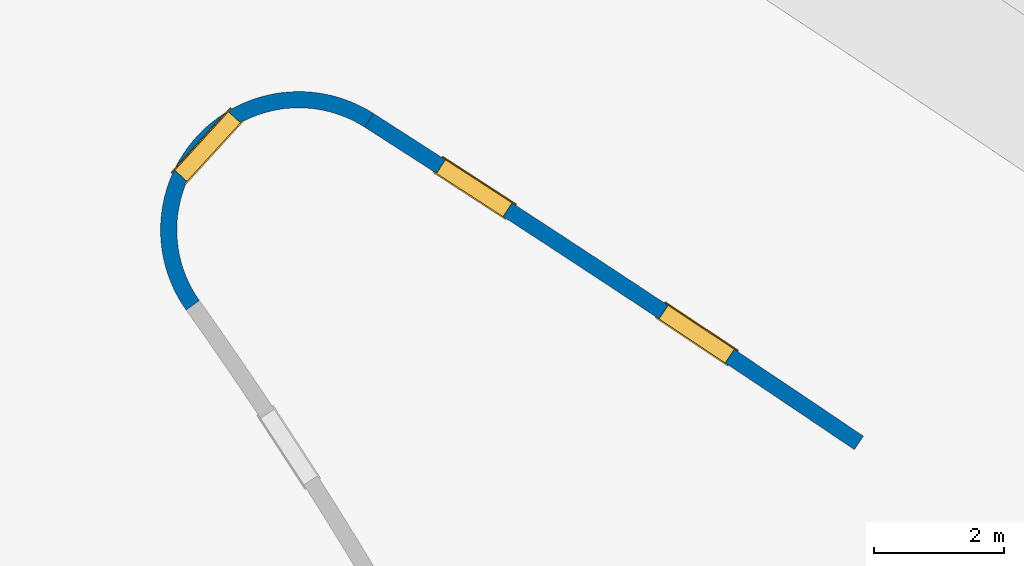
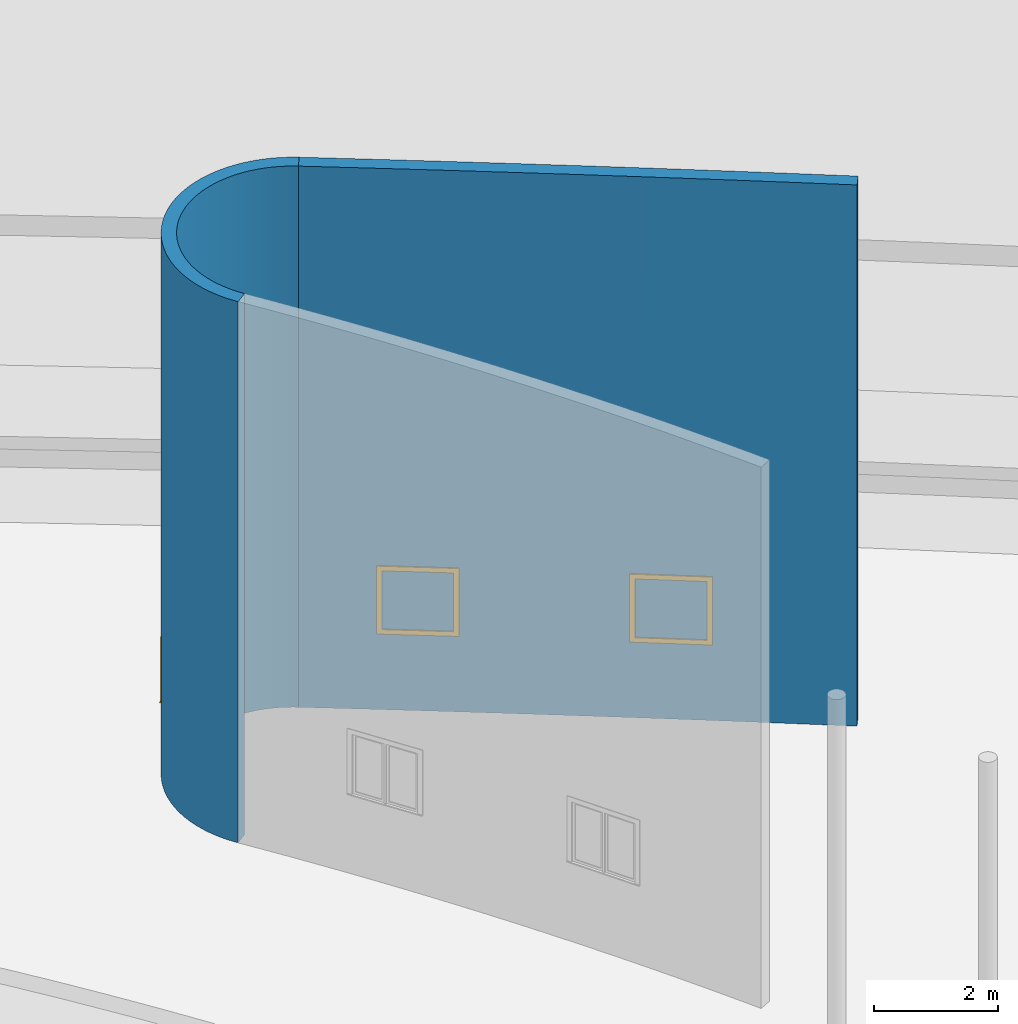
# One storey, part 14 of 39: 3 windows, 2 walls, 3 openings.
"""IFC2X3 building model written with IfcOpenShell, lengths in millimetres."""

from ifc_helpers import new_model, entity, si_unit, converted_unit, derived_unit, direction, frame, frame_2d, origin, origin_2d_with_axis, place, context, subcontext, project, spatial, polyline, circle_curve, parameter, trimmed, segment, composite_curve, rectangle, outline, extrude, clip, halfspace, source, transform, mapped, material, material_list, layer, layer_set, layer_usage, type_object, type_shapes, element, fill, save


model = new_model("IFC2X3")

# Units and contexts
model_context = context("Model", 3, precision=1e-06, world=origin(), true_north=direction((2.0, 6.12303176911189e-17, 1.0)))
context_of_model = context(None, 3, precision=1e-06, world=origin(), true_north=direction((2.0, 6.12303176911189e-17, 1.0)))
body_context = subcontext(model_context, "Body", "Model", "MODEL_VIEW")
ifc_project = project(units=[si_unit("LENGTHUNIT", "METRE", prefix="MILLI"), si_unit("AREAUNIT", "SQUARE_METRE", prefix="MILLI"), si_unit("VOLUMEUNIT", "CUBIC_METRE", prefix="MILLI"), converted_unit("PLANEANGLEUNIT", "DEGREE", entity("IfcRatioMeasure", 0.0174532925199433), si_unit("PLANEANGLEUNIT", "RADIAN"), dimensions=[0, 0, 0, 0, 0, 0, 0]), si_unit("MASSUNIT", "GRAM", prefix="KILO"), si_unit("TIMEUNIT", "SECOND"), si_unit("THERMODYNAMICTEMPERATUREUNIT", "KELVIN"), derived_unit("THERMALTRANSMITTANCEUNIT", [(si_unit("MASSUNIT", "GRAM", prefix="KILO"), 1), (si_unit("THERMODYNAMICTEMPERATUREUNIT", "KELVIN"), -1), (si_unit("TIMEUNIT", "SECOND"), -3)]), derived_unit("VOLUMETRICFLOWRATEUNIT", [(si_unit("LENGTHUNIT", "METRE"), 3), (si_unit("TIMEUNIT", "SECOND"), -1)])], contexts=[model_context, context_of_model])

# Site, building, storey
site_placement = place(None, origin())
site = spatial("IfcSite", under=ifc_project, at=site_placement, CompositionType="ELEMENT")
building_placement = place(site_placement, origin())
building = spatial("IfcBuilding", under=site, at=building_placement, CompositionType="ELEMENT")
storey_placement = place(building_placement, frame((0.0, 0.0, 4000.0)))
storey = spatial("IfcBuildingStorey", under=building, at=storey_placement, Name="Level 2", CompositionType="ELEMENT", Elevation=4000.0)

# Wall, opening, window
ifc_material_1 = material(Name="Concrete - Cast In Situ")
ifc_layer = layer(ifc_material_1, 250.0)
ifc_layer_set = layer_set([ifc_layer], Name="Basic Wall:Structure wall")
ifc_layer_usage_1 = layer_usage(ifc_layer_set, "AXIS2", "POSITIVE", -125.0)
wall_type = type_object("IfcWallType", Name="Basic Wall:Structure wall", PredefinedType="STANDARD", material=ifc_layer_set)
wall_1_placement = place(storey_placement, frame((324246.856857284, 630373.98662882, 362.0)))
wall_1 = element("IfcWallStandardCase", 1, at=wall_1_placement, inside=storey, type_object=wall_type, material=ifc_layer_usage_1, Name="Basic Wall:Structure wall", ObjectType="Basic Wall:Structure wall", context=body_context, shape_type="Clipping", body=[
    clip(extrude(outline(composite_curve([segment(trimmed(circle_curve(frame_2d((1629.61969874509, 1159.45661301403), x_axis=(1.0, 0.0)), 2125.0), [parameter(57.350329244171)], [parameter(215.431435435493)], True, "PARAMETER"), True, "CONTINUOUS"), segment(polyline([(-101.851231171568, -72.4660383133509), (101.851231171568, 72.4660383133509)]), True, "CONTINUOUS"), segment(trimmed(circle_curve(frame_2d((1629.61969874509, 1159.45661301403), x_axis=(1.0, 0.0)), 1875.0), [parameter(57.350329244171)], [parameter(215.431435435493)], True, "PARAMETER"), False, "CONTINUOUS"), segment(polyline([(2641.18392337272, 2738.17850728598), (2776.05915332311, 2948.67475985556)]), True, "CONTINUOUS")], self_intersect=False)), origin(), (0.0, 0.0, 1.0), 10638.0), halfspace(frame((2776.05915332309, 2948.67475985552, 10638.0)), False)),
])
opening_1_placement = place(wall_1_placement, frame((-20.1641166623605, 1841.36763574393, 1553.0)))
opening_1 = element("IfcOpeningElement", 2, at=opening_1_placement, cuts=wall_1, Name="M_Casement Dbl with Trim:1220 x 1220mm:1220 x 1220mm:1", ObjectType="Opening", context=body_context, shape_type="SweptSolid", body=[
    extrude(rectangle(XDim=1220.0, YDim=1220.0, at=frame_2d((610.0, 610.0), x_axis=(-1.0, 0.0))), frame((0.0, 0.0, 0.0), z_axis=(-0.738010038228833, 0.674789732786056, 0.0), x_axis=(0.0, 0.0, 1.0)), (0.0, 0.0, 1.0), 349.205370644085),
])
ifc_material_2 = material(Name="Glass")
ifc_material_3 = material(Name="Sash")
ifc_material_4 = material(Name="Trim")
ifc_material_list_1 = material_list([ifc_material_2, ifc_material_3, ifc_material_4])
ifc_material_list_2 = material_list([ifc_material_2, ifc_material_3, ifc_material_4])
window_style_1 = type_object("IfcWindowStyle", Name="1220 x 1220mm", ConstructionType="NOTDEFINED", OperationType="NOTDEFINED", ParameterTakesPrecedence=False, Sizeable=False, material=ifc_material_list_2)
shared_shape_1 = source(origin(), body_context, "Body", "SweptSolid", [
    extrude(rectangle(XDim=12.7, YDim=482.999999999998, at=origin_2d_with_axis()), frame((915.0, 208.775, 63.5000000000002), z_axis=(0.0, 0.0, 1.0), x_axis=(0.0, -1.0, 0.0)), (0.0, 0.0, 1.0), 1093.0),
    extrude(outline(polyline([(-285.949999999999, -590.950000000002), (285.949999999999, -590.950000000002), (285.949999999999, 590.950000000003), (-285.949999999999, 590.950000000003), (-285.949999999999, -590.950000000002)]), holes=[polyline([(-241.499999999998, -546.500000000003), (-241.499999999998, 546.500000000002), (241.5, 546.500000000002), (241.5, -546.500000000003), (-241.499999999998, -546.500000000003)])]), frame((915.0, 186.55, 610.0), z_axis=(0.0, 1.0, 0.0), x_axis=(1.0, 0.0, 0.0)), (0.0, 0.0, 1.0), 44.45),
    extrude(rectangle(XDim=25.7, YDim=1359.89999999999, at=frame_2d((-1.68753899743024e-14, 0.0), x_axis=(1.0, 0.0))), frame((610.0, 262.85, 0.0), z_axis=(0.0, 0.0, 1.0), x_axis=(0.0, -1.0, 0.0)), (0.0, 0.0, 1.0), 19.0500000000014),
    extrude(outline(polyline([(-568.700000000007, 590.949999999995), (613.200000000007, 590.949999999995), (613.200000000007, 679.949999999994), (-657.700000000005, 679.949999999994), (-657.700000000005, -679.949999999993), (613.200000000006, -679.949999999993), (613.200000000006, -590.949999999995), (-568.700000000007, -590.949999999995), (-568.700000000007, 590.949999999995)])), frame((610.0, 250.0, 632.250000000007), z_axis=(0.0, 1.0, 0.0), x_axis=(0.0, 0.0, -1.0)), (0.0, 0.0, 1.0), 13.0),
    extrude(outline(polyline([(-667.25000000001, -667.249999999998), (667.25000000001, -667.249999999998), (667.25000000001, 667.249999999998), (-667.25000000001, 667.249999999998), (-667.25000000001, -667.249999999998)]), holes=[polyline([(-578.250000000011, -578.250000000001), (-578.250000000011, 578.249999999997), (578.24999999999, 578.249999999997), (578.24999999999, -578.250000000001), (-578.250000000011, -578.250000000001)])]), frame((610.0, -19.0, 610.0), z_axis=(0.0, 1.0, 0.0), x_axis=(0.0, 0.0, -1.0)), (0.0, 0.0, 1.0), 19.0),
    extrude(rectangle(XDim=12.7, YDim=482.999999999998, at=frame_2d((1.68753899743024e-14, 4.2632564145606e-14), x_axis=(1.0, 0.0))), frame((305.0, 208.775, 63.4999999999994), z_axis=(0.0, 0.0, 1.0), x_axis=(0.0, 1.0, 0.0)), (0.0, 0.0, 1.0), 1093.0),
    extrude(outline(polyline([(-285.949999999999, -590.950000000002), (285.949999999999, -590.950000000002), (285.949999999999, 590.950000000002), (-285.949999999999, 590.950000000002), (-285.949999999999, -590.950000000002)]), holes=[polyline([(-241.499999999999, -546.500000000003), (-241.499999999999, 546.500000000001), (241.499999999999, 546.500000000001), (241.499999999999, -546.500000000003), (-241.499999999999, -546.500000000003)])]), frame((305.0, 186.55, 610.0), z_axis=(0.0, 1.0, 0.0), x_axis=(1.0, 0.0, 0.0)), (0.0, 0.0, 1.0), 44.45),
    extrude(outline(polyline([(-610.0, -610.0), (610.0, -610.0), (610.0, 610.0), (-610.0, 610.0), (-610.0, -610.0)]), holes=[polyline([(-578.25, -578.250000000001), (-578.25, 578.25), (578.249999999997, 578.25), (578.249999999997, -578.250000000001), (-578.25, -578.250000000001)])]), frame((610.0, 0.0, 610.0), z_axis=(0.0, 1.0, 0.0), x_axis=(1.0, 0.0, 0.0)), (0.0, 0.0, 1.0), 186.55),
    extrude(outline(polyline([(-610.0, -610.0), (610.0, -610.0), (610.0, 610.0), (-610.0, 610.0), (-610.0, -610.0)]), holes=[polyline([(-590.950000000002, -590.949999999996), (-590.950000000002, 590.95), (590.950000000003, 590.95), (590.950000000003, -590.949999999996), (-590.950000000002, -590.949999999996)])]), frame((610.0, 186.55, 610.0), z_axis=(0.0, 1.0, 0.0), x_axis=(0.0, 0.0, -1.0)), (0.0, 0.0, 1.0), 63.45),
    extrude(rectangle(XDim=63.5, YDim=38.0999999999998, at=frame_2d((-8.88178419700125e-15, 0.0), x_axis=(1.0, 0.0))), frame((610.0, 218.3, 19.0499999999995), z_axis=(0.0, 0.0, 1.0), x_axis=(0.0, 1.0, 0.0)), (0.0, 0.0, 1.0), 1181.90000000001),
])
type_shapes(window_style_1, [shared_shape_1])
window_1_placement = place(opening_1_placement, frame((-70.3288868727977, 64.3042889958015, 0.0), z_axis=(0.0, 0.0, 1.0), x_axis=(0.674789732786056, 0.738010038228833, 0.0)))
window_1 = element("IfcWindow", 3, at=window_1_placement, inside=storey, type_object=window_style_1, material=ifc_material_list_1, Name="M_Casement Dbl with Trim:1220 x 1220mm", ObjectType="1220 x 1220mm", OverallHeight=1220.0, OverallWidth=1219.99999999998, context=body_context, shape_type="MappedRepresentation", body=[
    mapped(shared_shape_1, transform((0.0, 0.0, 0.0), scale=1.0)),
])
fill(opening_1, window_1)

# Wall, openings, windows
ifc_layer_usage_2 = layer_usage(ifc_layer_set, "AXIS2", "NEGATIVE", 125.0)
wall_2_placement = place(storey_placement, frame((334483.445268421, 628259.485978827, 362.0)))
wall_2 = element("IfcWallStandardCase", 4, at=wall_2_placement, inside=storey, type_object=wall_type, material=ifc_layer_usage_2, Name="Basic Wall:Structure wall", ObjectType="Basic Wall:Structure wall", context=body_context, shape_type="Clipping", body=[
    clip(extrude(outline(composite_curve([segment(trimmed(circle_curve(frame_2d((-201222.502191845, -297336.080614485), x_axis=(1.0, 0.0)), 358900.40331226), [parameter(55.9117821127716)], [parameter(57.3503292441685)], True, "PARAMETER"), False, "CONTINUOUS"), segment(polyline([(-70.0585878955262, -103.521950629198), (70.0585878935857, 103.521950630584)]), True, "CONTINUOUS"), segment(trimmed(circle_curve(frame_2d((-201222.502191845, -297336.080614485), x_axis=(1.0, 0.0)), 359150.40331226), [parameter(55.9117821127716)], [parameter(57.3503292441685)], True, "PARAMETER"), True, "CONTINUOUS"), segment(polyline([(-7460.52925781992, 5063.1754098524), (-7595.40448777218, 4852.67915728408)]), True, "CONTINUOUS")], self_intersect=False)), origin(), (0.0, 0.0, 1.0), 10638.0), halfspace(frame((-7595.40448777034, 4852.67915728292, 10638.0)), False)),
])
opening_2_placement = place(wall_2_placement, frame((-6626.48655513259, 3931.46045422135, 1553.0)))
opening_2 = element("IfcOpeningElement", 5, at=opening_2_placement, cuts=wall_2, Name="M_Casement Dbl with Trim:1220 x 1220mm:1220 x 1220mm:1", ObjectType="Opening", context=body_context, shape_type="SweptSolid", body=[
    extrude(rectangle(XDim=1220.0, YDim=1220.0, at=frame_2d((610.0, 610.0), x_axis=(-1.0, 0.0))), frame((0.0, 0.0, 0.0), z_axis=(0.544007246809993, 0.839080517839743, 0.0), x_axis=(0.0, 0.0, 1.0)), (0.0, 0.0, 1.0), 250.539969129551),
])
opening_3_placement = place(wall_2_placement, frame((-3209.169925568, 1696.46083890477, 1553.0)))
opening_3 = element("IfcOpeningElement", 6, at=opening_3_placement, cuts=wall_2, Name="M_Casement Dbl with Trim:1220 x 1220mm:1220 x 1220mm:1", ObjectType="Opening", context=body_context, shape_type="SweptSolid", body=[
    extrude(rectangle(XDim=1220.0, YDim=1220.0, at=frame_2d((610.0, 610.0), x_axis=(-1.0, 0.0))), frame((0.0, 0.0, 0.0), z_axis=(0.553524914269953, 0.832832617806508, 0.0), x_axis=(0.0, 0.0, 1.0)), (0.0, 0.0, 1.0), 250.539969129551),
])
ifc_material_list_3 = material_list([ifc_material_2, ifc_material_3, ifc_material_4])
ifc_material_list_4 = material_list([ifc_material_2, ifc_material_3, ifc_material_4])
window_style_2 = type_object("IfcWindowStyle", Name="1220 x 1220mm", ConstructionType="NOTDEFINED", OperationType="NOTDEFINED", ParameterTakesPrecedence=False, Sizeable=False, material=ifc_material_list_4)
shared_shape_2 = source(origin(), body_context, "Body", "SweptSolid", [
    extrude(rectangle(XDim=12.7, YDim=482.999999999998, at=origin_2d_with_axis()), frame((915.0, 208.775, 63.5000000000002), z_axis=(0.0, 0.0, 1.0), x_axis=(0.0, -1.0, 0.0)), (0.0, 0.0, 1.0), 1093.0),
    extrude(outline(polyline([(-285.949999999999, -590.950000000002), (285.949999999999, -590.950000000002), (285.949999999999, 590.950000000003), (-285.949999999999, 590.950000000003), (-285.949999999999, -590.950000000002)]), holes=[polyline([(-241.499999999998, -546.500000000003), (-241.499999999998, 546.500000000002), (241.5, 546.500000000002), (241.5, -546.500000000003), (-241.499999999998, -546.500000000003)])]), frame((915.0, 186.55, 610.0), z_axis=(0.0, 1.0, 0.0), x_axis=(1.0, 0.0, 0.0)), (0.0, 0.0, 1.0), 44.45),
    extrude(rectangle(XDim=25.7, YDim=1359.89999999999, at=frame_2d((-1.68753899743024e-14, 0.0), x_axis=(1.0, 0.0))), frame((610.0, 262.85, 0.0), z_axis=(0.0, 0.0, 1.0), x_axis=(0.0, -1.0, 0.0)), (0.0, 0.0, 1.0), 19.0500000000014),
    extrude(outline(polyline([(-568.700000000007, 590.949999999995), (613.200000000007, 590.949999999995), (613.200000000007, 679.949999999994), (-657.700000000005, 679.949999999994), (-657.700000000005, -679.949999999993), (613.200000000006, -679.949999999993), (613.200000000006, -590.949999999995), (-568.700000000007, -590.949999999995), (-568.700000000007, 590.949999999995)])), frame((610.0, 250.0, 632.250000000007), z_axis=(0.0, 1.0, 0.0), x_axis=(0.0, 0.0, -1.0)), (0.0, 0.0, 1.0), 13.0),
    extrude(outline(polyline([(-667.25000000001, -667.249999999998), (667.25000000001, -667.249999999998), (667.25000000001, 667.249999999998), (-667.25000000001, 667.249999999998), (-667.25000000001, -667.249999999998)]), holes=[polyline([(-578.250000000011, -578.250000000001), (-578.250000000011, 578.249999999997), (578.24999999999, 578.249999999997), (578.24999999999, -578.250000000001), (-578.250000000011, -578.250000000001)])]), frame((610.0, -19.0, 610.0), z_axis=(0.0, 1.0, 0.0), x_axis=(0.0, 0.0, -1.0)), (0.0, 0.0, 1.0), 19.0),
    extrude(rectangle(XDim=12.7, YDim=482.999999999998, at=frame_2d((1.68753899743024e-14, 4.2632564145606e-14), x_axis=(1.0, 0.0))), frame((305.0, 208.775, 63.4999999999994), z_axis=(0.0, 0.0, 1.0), x_axis=(0.0, 1.0, 0.0)), (0.0, 0.0, 1.0), 1093.0),
    extrude(outline(polyline([(-285.949999999999, -590.950000000002), (285.949999999999, -590.950000000002), (285.949999999999, 590.950000000002), (-285.949999999999, 590.950000000002), (-285.949999999999, -590.950000000002)]), holes=[polyline([(-241.499999999999, -546.500000000003), (-241.499999999999, 546.500000000001), (241.499999999999, 546.500000000001), (241.499999999999, -546.500000000003), (-241.499999999999, -546.500000000003)])]), frame((305.0, 186.55, 610.0), z_axis=(0.0, 1.0, 0.0), x_axis=(1.0, 0.0, 0.0)), (0.0, 0.0, 1.0), 44.45),
    extrude(outline(polyline([(-610.0, -610.0), (610.0, -610.0), (610.0, 610.0), (-610.0, 610.0), (-610.0, -610.0)]), holes=[polyline([(-578.25, -578.250000000001), (-578.25, 578.25), (578.249999999997, 578.25), (578.249999999997, -578.250000000001), (-578.25, -578.250000000001)])]), frame((610.0, 0.0, 610.0), z_axis=(0.0, 1.0, 0.0), x_axis=(1.0, 0.0, 0.0)), (0.0, 0.0, 1.0), 186.55),
    extrude(outline(polyline([(-610.0, -610.0), (610.0, -610.0), (610.0, 610.0), (-610.0, 610.0), (-610.0, -610.0)]), holes=[polyline([(-590.950000000002, -590.949999999996), (-590.950000000002, 590.95), (590.950000000003, 590.95), (590.950000000003, -590.949999999996), (-590.950000000002, -590.949999999996)])]), frame((610.0, 186.55, 610.0), z_axis=(0.0, 1.0, 0.0), x_axis=(0.0, 0.0, -1.0)), (0.0, 0.0, 1.0), 63.45),
    extrude(rectangle(XDim=63.5, YDim=38.0999999999998, at=frame_2d((-8.88178419700125e-15, 0.0), x_axis=(1.0, 0.0))), frame((610.0, 218.3, 19.0499999999995), z_axis=(0.0, 0.0, 1.0), x_axis=(0.0, 1.0, 0.0)), (0.0, 0.0, 1.0), 1181.90000000001),
])
type_shapes(window_style_2, [shared_shape_2])
window_2_placement = place(opening_2_placement, frame((136.283721061482, 210.204948393512, 0.0), z_axis=(0.0, 0.0, 1.0), x_axis=(0.839080517839743, -0.544007246809993, 0.0)))
window_2 = element("IfcWindow", 7, at=window_2_placement, inside=storey, type_object=window_style_2, material=ifc_material_list_3, Name="M_Casement Dbl with Trim:1220 x 1220mm", ObjectType="1220 x 1220mm", OverallHeight=1220.0, OverallWidth=1220.00000000005, context=body_context, shape_type="MappedRepresentation", body=[
    mapped(shared_shape_2, transform((0.0, 0.0, 0.0), scale=1.0)),
])
fill(opening_2, window_2)
ifc_material_list_5 = material_list([ifc_material_2, ifc_material_3, ifc_material_4])
window_3_placement = place(opening_3_placement, frame((138.668070065847, 208.639735668432, 0.0), z_axis=(0.0, 0.0, 1.0), x_axis=(0.832832617806508, -0.553524914269953, 0.0)))
window_3 = element("IfcWindow", 8, at=window_3_placement, inside=storey, type_object=window_style_2, material=ifc_material_list_5, Name="M_Casement Dbl with Trim:1220 x 1220mm", ObjectType="1220 x 1220mm", OverallHeight=1220.0, OverallWidth=1220.00000000004, context=body_context, shape_type="MappedRepresentation", body=[
    mapped(shared_shape_2, transform((0.0, 0.0, 0.0), scale=1.0)),
])
fill(opening_3, window_3)

save(model, "model.ifc")
